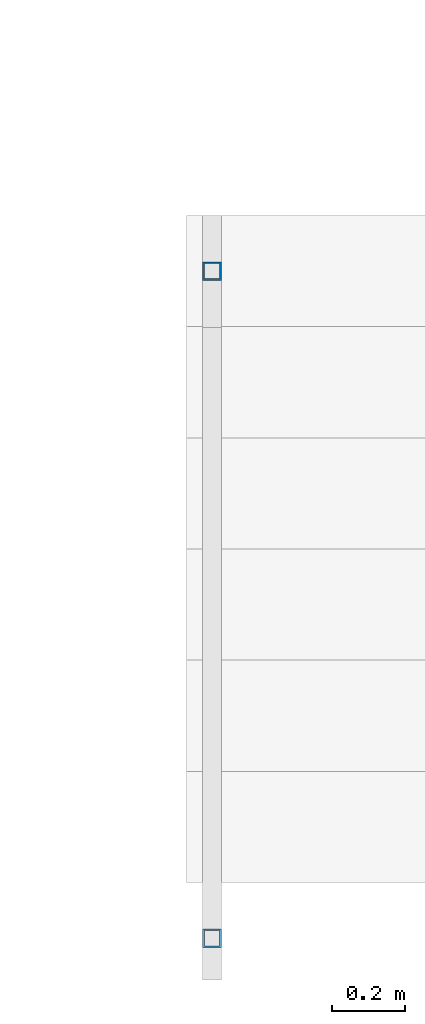
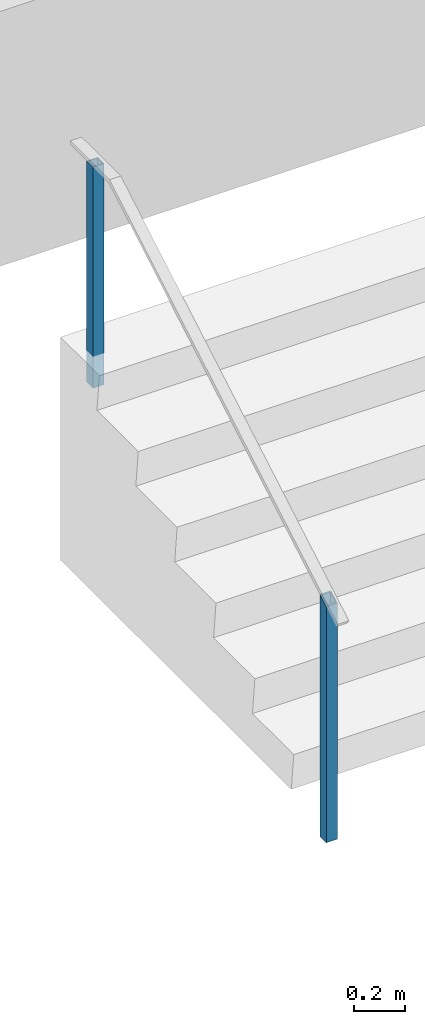
# One storey, part 896 of 1763: 2 columns, 1 element without a shape of its own.
"""IFC2X3 building model written with IfcOpenShell, lengths in millimetres."""

import ifcopenshell
import ifcopenshell.guid

model = None  # the IFC model being written
_history = None  # IfcOwnerHistory: only IFC2X3 demands one
_inside = {}  # id of a spatial element -> (the spatial element, [elements in it])
_under = {}  # id of a project, library or spatial element -> (it, [spatial elements below it])
_declared = {}  # id of a project -> (the project, [libraries it declares])
_typed = {}  # id of a type object -> (the type object, [elements of that type])
_made_of = {}  # id of a material, layer set ... -> (it, [elements and type objects made of it])


def new_model(schema):
    """Start an empty IFC model of exactly this schema.

    Asked for "IFC4X3", IfcOpenShell would pick the latest addendum, in which some entities
    have other attributes; the version numbers below select the first issue.
    IFC2X3 requires an IfcOwnerHistory on every rooted entity: one is made here for all.
    """
    global model, _history
    if schema == "IFC4X3":
        model = ifcopenshell.file(schema_version=(4, 3, 0, 0))
    else:
        model = ifcopenshell.file(schema=schema)
    _inside.clear()
    _under.clear()
    _declared.clear()
    _typed.clear()
    _made_of.clear()
    _history = None
    if model.schema == "IFC2X3":
        org = make("IfcOrganization", Name="unknown")
        user = make(
            "IfcPersonAndOrganization",
            ThePerson=make("IfcPerson", FamilyName="unknown"),
            TheOrganization=org,
        )
        app = make(
            "IfcApplication",
            ApplicationDeveloper=org,
            Version="unknown",
            ApplicationFullName="unknown",
            ApplicationIdentifier="unknown",
        )
        _history = make(
            "IfcOwnerHistory",
            OwningUser=user,
            OwningApplication=app,
            ChangeAction="ADDED",
            CreationDate=0,
        )
    return model


def make(cls, **values):
    """One entity of the class cls with the attributes given. An attribute that is None is left unset."""
    return model.create_entity(
        cls, **{name: value for name, value in values.items() if value is not None}
    )


def rooted(cls, **values):
    """An entity with a GlobalId (a new one), such as an element, a storey or a relation."""
    return make(cls, GlobalId=ifcopenshell.guid.new(), OwnerHistory=_history, **values)


def si_unit(unit_type, name, prefix=None):
    """IfcSIUnit, for example si_unit("LENGTHUNIT", "METRE", prefix="MILLI")."""
    return make("IfcSIUnit", UnitType=unit_type, Prefix=prefix, Name=name)


def assignment(units):
    """IfcUnitAssignment: the units of a project."""
    return None if units is None else make("IfcUnitAssignment", Units=units)


def point(xyz):
    """IfcCartesianPoint."""
    return None if xyz is None else make("IfcCartesianPoint", Coordinates=xyz)


def direction(xyz):
    """IfcDirection."""
    return None if xyz is None else make("IfcDirection", DirectionRatios=xyz)


def frame(location, z_axis=None, x_axis=None):
    """IfcAxis2Placement3D, a coordinate frame: its origin and axes. An axis left out is left unset."""
    return make(
        "IfcAxis2Placement3D",
        Location=point(location),
        Axis=direction(z_axis),
        RefDirection=direction(x_axis),
    )


def origin_with_axes():
    """The frame at (0, 0, 0) with the z axis (0, 0, 1) and the x axis (1, 0, 0) written out."""
    return frame((0.0, 0.0, 0.0), z_axis=(0.0, 0.0, 1.0), x_axis=(1.0, 0.0, 0.0))


def place(relative_to, where):
    """IfcLocalPlacement: puts the frame where relative to a parent placement (None: the world)."""
    return make(
        "IfcLocalPlacement", PlacementRelTo=relative_to, RelativePlacement=where
    )


def context(
    kind, dimensions, precision=None, world=None, true_north=None, identifier=None
):
    """IfcGeometricRepresentationContext, for example the 3D "Model" context."""
    return make(
        "IfcGeometricRepresentationContext",
        ContextIdentifier=identifier,
        ContextType=kind,
        CoordinateSpaceDimension=dimensions,
        Precision=precision,
        WorldCoordinateSystem=world,
        TrueNorth=true_north,
    )


def subcontext(parent, identifier, kind, view, scale=None):
    """IfcGeometricRepresentationSubContext, for example "Body" below "Model"."""
    return make(
        "IfcGeometricRepresentationSubContext",
        ContextIdentifier=identifier,
        ContextType=kind,
        ParentContext=parent,
        TargetScale=scale,
        TargetView=view,
    )


def project(units=None, contexts=None):
    """IfcProject with its units and contexts."""
    return rooted(
        "IfcProject",
        Name="project",
        RepresentationContexts=contexts,
        UnitsInContext=assignment(units),
    )


def spatial(cls, under=None, at=None, **own):
    """A site, building, storey or space (cls), placed at a placement, below another one or the project."""
    s = rooted(cls, ObjectPlacement=at, **own)
    if under is not None:
        _under.setdefault(under.id(), (under, []))[1].append(s)
    return s


def faces_of(points, faces, orient=None, outer=None):
    """IfcFace entities. A face is a list of loops; a loop is a list of indices into points, from 0.

    orient and outer hold one flag for each loop. By default every Orientation is true, the
    first loop of a face is its IfcFaceOuterBound and the others are IfcFaceBound.
    """
    made = []
    for i, loops in enumerate(faces):
        bounds = []
        for j, loop in enumerate(loops):
            is_outer = j == 0 if outer is None else outer[i][j]
            bounds.append(
                make(
                    "IfcFaceOuterBound" if is_outer else "IfcFaceBound",
                    Bound=make("IfcPolyLoop", Polygon=[points[k] for k in loop]),
                    Orientation=True if orient is None else orient[i][j],
                )
            )
        made.append(make("IfcFace", Bounds=bounds))
    return made


def faceted_brep(points, faces, orient=None, outer=None, voids=None):
    """IfcFacetedBrep: a solid bounded by flat faces; with voids (closed shells), ...WithVoids."""
    shared = [point(p) for p in points]
    hull = make("IfcClosedShell", CfsFaces=faces_of(shared, faces, orient, outer))
    if voids is None:
        return make("IfcFacetedBrep", Outer=hull)
    return make(
        "IfcFacetedBrepWithVoids",
        Outer=hull,
        Voids=[
            make(cls, CfsFaces=faces_of(shared, fs, o, b)) for cls, fs, o, b in voids
        ],
    )


def shape(context_of_items, identifier, shape_type, items):
    """IfcShapeRepresentation: the items that make up one representation, for example the "Body"."""
    return make(
        "IfcShapeRepresentation",
        ContextOfItems=context_of_items,
        RepresentationIdentifier=identifier,
        RepresentationType=shape_type,
        Items=items,
    )


def material(Name=None, Category=None):
    """IfcMaterial."""
    return make("IfcMaterial", Name=Name, Category=Category)


def made_of(thing, what):
    """Note that an element or type object is made of a material, layer set ...; save() writes the relation."""
    if what is not None:
        _made_of.setdefault(what.id(), (what, []))[1].append(thing)
    return thing


def type_object(cls, material=None, **own):
    """A type object (cls), such as IfcWallType, which elements share."""
    return made_of(rooted(cls, **own), material)


def element(
    cls,
    number,
    at=None,
    inside=None,
    cuts=None,
    type_object=None,
    material=None,
    context=None,
    identifier="Body",
    shape_type=None,
    held_by="IfcProductDefinitionShape",
    body=None,
    shapes=None,
    **own,
):
    """One element of the class cls, such as IfcWall. Its Tag is "e" and its number.

    at: its placement. inside: the storey or other place that contains it. cuts: it is an
    opening in that element (IfcRelVoidsElement). A single representation is given by context,
    identifier, shape_type and body (its items); several are given by shapes. held_by: the class
    of the entity that holds the representations. save() writes the other relations.
    """
    e = rooted(cls, Tag="e%d" % number, ObjectPlacement=at, **own)
    if body is not None:
        shapes = [shape(context, identifier, shape_type, body)]
    if shapes is not None:
        e.Representation = make(held_by, Representations=shapes)
    if inside is not None:
        _inside.setdefault(inside.id(), (inside, []))[1].append(e)
    if cuts is not None:
        rooted(
            "IfcRelVoidsElement", RelatingBuildingElement=cuts, RelatedOpeningElement=e
        )
    if type_object is not None:
        _typed.setdefault(type_object.id(), (type_object, []))[1].append(e)
    return made_of(e, material)


def aggregate(whole, parts):
    """IfcRelAggregates: a whole, such as a stair, and the parts it consists of."""
    return rooted("IfcRelAggregates", RelatingObject=whole, RelatedObjects=parts)


def save(model, path):
    """Write the relations noted so far, then the file.

    IfcRelAggregates (storeys below a building ...), IfcRelContainedInSpatialStructure (elements
    in a storey), IfcRelDefinesByType, IfcRelAssociatesMaterial and IfcRelDeclares: one each for
    every whole, place, type object, material and project.
    """
    for whole, parts in _under.values():
        aggregate(whole, parts)
    for where, things in _inside.values():
        rooted(
            "IfcRelContainedInSpatialStructure",
            RelatedElements=things,
            RelatingStructure=where,
        )
    for kind, things in _typed.values():
        rooted("IfcRelDefinesByType", RelatedObjects=things, RelatingType=kind)
    for what, things in _made_of.values():
        rooted("IfcRelAssociatesMaterial", RelatedObjects=things, RelatingMaterial=what)
    for by, libraries in _declared.values():
        rooted("IfcRelDeclares", RelatingContext=by, RelatedDefinitions=libraries)
    model.write(path)


model = new_model("IFC2X3")

# Units and contexts
model_context = context("Model", 3, precision=1e-05, world=origin_with_axes())
body_context = subcontext(model_context, "Body", "Model", "MODEL_VIEW")
ifc_project = project(units=[si_unit("LENGTHUNIT", "METRE", prefix="MILLI"), si_unit("AREAUNIT", "SQUARE_METRE"), si_unit("VOLUMEUNIT", "CUBIC_METRE"), si_unit("MASSUNIT", "GRAM", prefix="KILO"), si_unit("TIMEUNIT", "SECOND"), si_unit("PLANEANGLEUNIT", "RADIAN"), si_unit("SOLIDANGLEUNIT", "STERADIAN"), si_unit("THERMODYNAMICTEMPERATUREUNIT", "DEGREE_CELSIUS"), si_unit("LUMINOUSINTENSITYUNIT", "LUMEN")], contexts=[model_context])

# Site, building, storey
site_placement = place(None, origin_with_axes())
site = spatial("IfcSite", under=ifc_project, at=site_placement, CompositionType="ELEMENT")
building_placement = place(site_placement, origin_with_axes())
building = spatial("IfcBuilding", under=site, at=building_placement, Name="Undefined", CompositionType="ELEMENT")
storey_placement = place(building_placement, origin_with_axes())
storey = spatial("IfcBuildingStorey", under=building, at=storey_placement, Name="Undefined", CompositionType="ELEMENT", Elevation=0.0)

# Assembly, columns
assembly_placement = place(storey_placement, origin_with_axes())
assembly = element("IfcElementAssembly", 1, at=assembly_placement, inside=storey, Name="HANDRAIL", AssemblyPlace="NOTDEFINED", PredefinedType="RIGID_FRAME")
ifc_material = material()
column_type = type_object("IfcColumnType", Name="2X2X3/16 SQUARE TUBE SS", PredefinedType="NOTDEFINED")
column_1_placement = place(assembly_placement, frame((-34879.9872736984, -19034.1250043753, 4114.8), z_axis=(-1.0, 0.0, 0.0), x_axis=(0.0, 0.0, 1.0)))
column_1 = element("IfcColumn", 2, at=column_1_placement, type_object=column_type, material=ifc_material, Name="POST TUBE", ObjectType="2X2X3/16 SQUARE TUBE SS", context=body_context, shape_type="Brep", body=[
    faceted_brep([(0.0, 20.6375000000007, -20.6374999999971), (0.0, -20.6375000000007, -20.6374999999971), (1132.63432765349, -20.6375000000007, -20.6374999999971), (1156.71140979222, 20.6375000000007, -20.6374999999971), (0.0, -20.6375000000007, 20.6374999999971), (1132.63432765349, -20.6375000000007, 20.6374999999971), (0.0, 20.6375000000007, 20.6374999999971), (1156.71140979222, 20.6375000000007, 20.6374999999971), (-1.45519152283669e-11, 25.4000000000015, -25.3999999999869), (1.45519152283669e-11, 25.4000000000015, 25.3999999999796), (1159.48953465438, 25.4000000000015, 25.4000000000015), (1159.48953465438, 25.4000000000015, -25.4000000000015), (0.0, -25.4000000000015, 25.3999999999942), (1129.85620279133, -25.4000000000015, 25.4000000000015), (-1.45519152283669e-11, -25.4000000000015, -25.3999999999869), (1129.85620279133, -25.4000000000015, -25.4000000000015)], [[[0, 1, 2, 3]], [[1, 4, 5, 2]], [[4, 6, 7, 5]], [[6, 0, 3, 7]], [[8, 9, 10, 11]], [[9, 12, 13, 10]], [[12, 14, 15, 13]], [[14, 8, 11, 15]], [[13, 15, 11, 10], [5, 7, 3, 2]], [[14, 12, 9, 8], [6, 4, 1, 0]]]),
])
column_2_placement = place(assembly_placement, frame((-34879.9872736984, -17205.3250104788, 5181.6), z_axis=(-1.0, 0.0, 0.0), x_axis=(0.0, 0.0, 1.0)))
column_2 = element("IfcColumn", 3, at=column_2_placement, type_object=column_type, material=ifc_material, Name="POST TUBE", ObjectType="2X2X3/16 SQUARE TUBE SS", context=body_context, shape_type="Brep", body=[
    faceted_brep([(-1.45519152283669e-11, -25.4000000000015, -25.3999999999869), (-1.45519152283669e-11, 25.4000000000015, -25.3999999999869), (1057.27498047955, 25.4000000000015, -25.4000000000015), (1057.27498047955, -25.4000000000015, -25.4000000000015), (0.0, -25.4000000000015, 25.3999999999942), (1057.27498047955, -25.4000000000015, 25.4000000000015), (1.45519152283669e-11, 25.4000000000015, 25.3999999999796), (1057.27498047955, 25.4000000000015, 25.4000000000015), (0.0, 20.6375000000007, 20.6374999999971), (0.0, -20.6375000000007, 20.6374999999971), (0.0, -20.6375000000007, -20.6374999999971), (0.0, 20.6375000000007, -20.6374999999971), (1057.27498047955, -20.6375000000007, 20.6374999999971), (1057.27498047955, -20.6375000000007, -20.6374999999971), (1057.27498047955, 20.6375000000007, -20.6374999999971), (1057.27498047955, 20.6375000000007, 20.6374999999971)], [[[0, 1, 2, 3]], [[4, 0, 3, 5]], [[6, 4, 5, 7]], [[1, 6, 7, 2]], [[0, 4, 6, 1], [8, 9, 10, 11]], [[10, 9, 12, 13]], [[11, 10, 13, 14]], [[8, 11, 14, 15]], [[9, 8, 15, 12]], [[2, 7, 5, 3], [14, 13, 12, 15]]]),
])
aggregate(assembly, [column_1, column_2])

save(model, "model.ifc")
